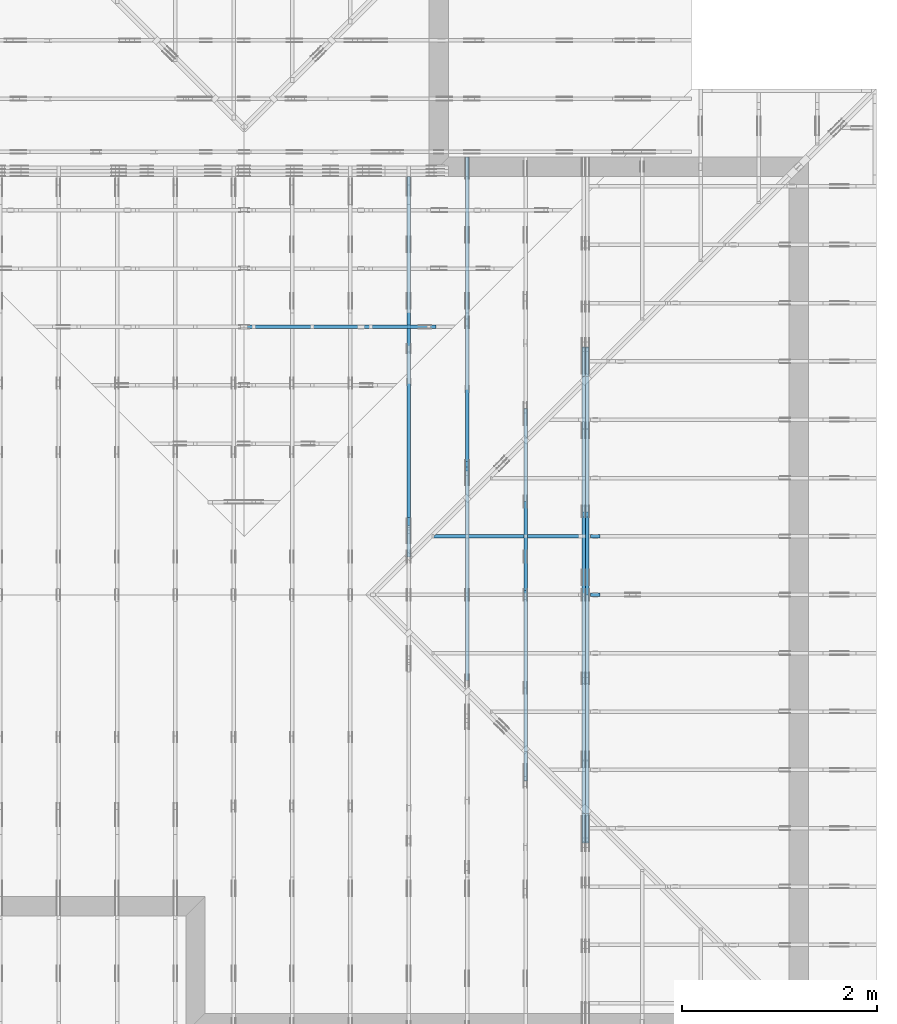
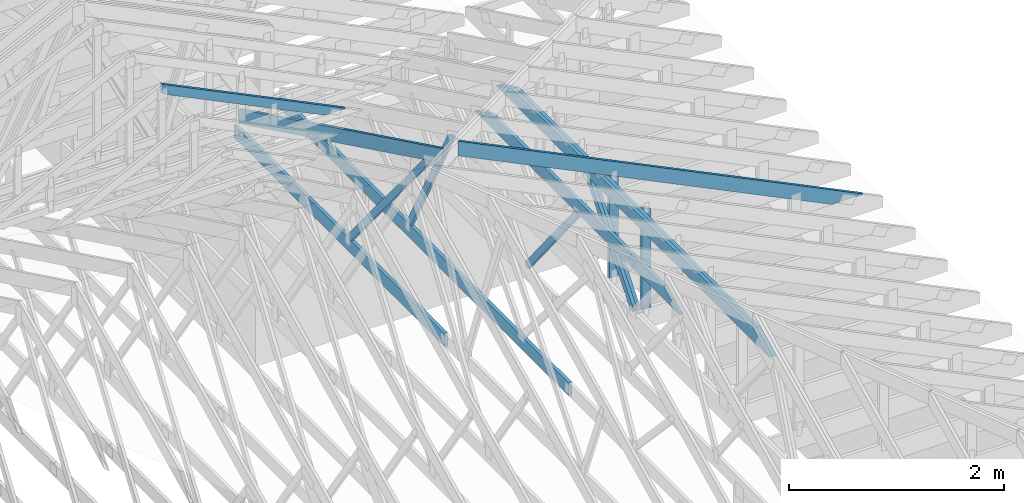
# One storey, part 33 of 159: 15 members, 7 elements without a shape of their own.
"""IFC2X3 building model written with IfcOpenShell, lengths in millimetres."""

from ifc_helpers import new_model, si_unit, frame, origin, origin_with_axes, origin_2d, place, context, project, spatial, faceted_brep, element, aggregate, save


model = new_model("IFC2X3")

# Units and contexts
model_context = context("Model", 3, precision=1e-05, world=origin())
plan_context = context("Plan", 2, precision=1e-05, world=origin_2d())
ifc_project = project(units=[si_unit("LENGTHUNIT", "METRE", prefix="MILLI"), si_unit("AREAUNIT", "SQUARE_METRE"), si_unit("VOLUMEUNIT", "CUBIC_METRE"), si_unit("SOLIDANGLEUNIT", "STERADIAN"), si_unit("PLANEANGLEUNIT", "RADIAN"), si_unit("MASSUNIT", "GRAM"), si_unit("TIMEUNIT", "SECOND"), si_unit("THERMODYNAMICTEMPERATUREUNIT", "DEGREE_CELSIUS"), si_unit("LUMINOUSINTENSITYUNIT", "LUMEN")], contexts=[model_context, plan_context])

# Site, building, storey
site_placement = place(None, origin_with_axes())
site = spatial("IfcSite", under=ifc_project, at=site_placement, CompositionType="ELEMENT")
building_placement = place(site_placement, origin_with_axes())
building = spatial("IfcBuilding", under=site, at=building_placement, Name="Plan 1", CompositionType="ELEMENT")
storey_placement = place(building_placement, origin_with_axes())
storey = spatial("IfcBuildingStorey", under=building, at=storey_placement, Name="Etasje 1", CompositionType="ELEMENT", Elevation=0.0)

# Assembly, members
assembly_1_placement = place(storey_placement, frame((16311.022261404749, -699.9989301294839, 1.1021457184401395e-15), z_axis=(1.0, -6.123031769111886e-17, 6.123031769111886e-17), x_axis=(6.123031769111886e-17, 1.0, 0.0)))
assembly_1 = element("IfcElementAssembly", 1, at=assembly_1_placement, inside=storey, Name="V8 (33)", AssemblyPlace="FACTORY", PredefinedType="TRUSS")
member_1_placement = place(assembly_1_placement, frame((5561.041284732537, 2315.452245697593, -36.00000332936904), z_axis=(0.0, 0.0, 1.0), x_axis=(0.8987940462991668, -0.4383711467890778, 0.0)))
member_1 = element("IfcMember", 2, at=member_1_placement, Name="V8-O18", context=model_context, shape_type="Brep", body=[
    faceted_brep([(112.23809390655876, 1.0096862743225188e-05, 36.00000636883472), (40.05366994714767, 148.00000490950697, 36.00000332936904), (-1.0658141036401503e-14, 148.00000458156322, 3.116920723300609e-06), (72.18442395941081, 9.768919051467151e-06, 6.15638617773584e-06), (4284.582819617043, 4.91022742784666e-06, 3.3293690364644135e-06), (4284.582819617043, 4.910227438044557e-06, 36.00000332936904), (112.23809305454324, 4.910228204466536e-06, 36.00000332936904), (72.18442407871316, 4.910228201626135e-06, 3.3293690364644135e-06), (7.641074262210168e-08, 148.0000049095188, 3.3293690364644135e-06), (40.05366905224082, 148.0000049095188, 36.00000332936904), (4212.398437576409, 148.00000490951854, 36.00000332936904), (4212.398437576409, 148.00000490951854, 3.3293690364644135e-06), (4212.3985236506915, 148.00000448254082, 1.9341692265584247e-06), (4212.398523650691, 148.00000448254082, 36.00000332936904), (4284.58294894472, -2.2737367544323206e-13, 36.00000302469259), (4284.58294894472, -2.2737367544323206e-13, -3.2311742677852644e-27), (4212.398396509646, 148.00000490829825, 36.00000332936904), (40.05366994714768, 148.00000490829825, 36.00000332936904), (112.23809530115113, 4.909506969852373e-06, 36.00000332936904), (4284.582966822146, 4.909506969852373e-06, 36.00000332936904), (8.594303608333576e-05, 148.00000490951788, 3.329369036464424e-06), (4212.398523443036, 148.00000490951788, 3.3293695523174132e-06), (4284.5829487970395, 4.908298251393717e-06, 3.329369561157164e-06), (72.18465625553517, 4.908298251393717e-06, 3.3293690453041925e-06)], [[[0, 1, 2, 3]], [[4, 5, 6, 7]], [[8, 9, 10, 11]], [[12, 13, 14, 15]], [[16, 17, 18, 19]], [[20, 21, 22, 23]]]),
])
member_2_placement = place(assembly_1_placement, frame((9501.9990234375, 371.000000000001, -36.0), z_axis=(0.0, 0.0, 1.0), x_axis=(-1.0, 1.2246063538223773e-16, 0.0)))
member_2 = element("IfcMember", 3, at=member_2_placement, Name="V8-U39", context=model_context, shape_type="Brep", body=[
    faceted_brep([(3910.81787109375, 148.00000000000148, 36.0), (0.0, 148.00000000000148, 36.0), (0.0, 1.0231815394945443e-12, 36.0), (3910.81787109375, 1.0231815394945443e-12, 36.0), (0.0, 148.00000000000148, 0.0), (3910.81787109375, 148.00000000000148, 4.789212413583509e-13), (3910.81787109375, 1.0231815394945443e-12, 4.789212413583509e-13), (0.0, 1.0231815394945443e-12, 0.0), (9.331764886155725e-05, 1.0231815394945443e-12, 0.0), (9.331764886376154e-05, 1.0231815394945443e-12, 36.0), (9.331764888188571e-05, 148.000000000001, 36.0), (9.331764887968142e-05, 148.000000000001, -1.1097486696621528e-30), (3910.817727755755, 3.047997282014717e-13, -1.8662984189942796e-29), (3910.817727755755, 3.07004019638352e-13, 36.0), (9.331764886155725e-05, 1.0253858382043776e-12, 36.0), (9.331764886155725e-05, 1.0231815467674973e-12, -4.453252306857598e-37), (3910.817727755755, 147.99999999999997, 0.0), (3910.817727755755, 147.99999999999997, 36.0), (3910.817727755755, 0.0, 36.0), (3910.817727755755, 0.0, 0.0), (9.331764886155725e-05, 148.000000000001, 0.0), (9.331764886155725e-05, 148.000000000001, 36.0), (3910.817727755755, 147.9999999999999, 36.0), (3910.817727755755, 147.9999999999999, -4.733165431326071e-30)], [[[0, 1, 2, 3]], [[4, 5, 6, 7]], [[8, 9, 10, 11]], [[12, 13, 14, 15]], [[16, 17, 18, 19]], [[20, 21, 22, 23]]]),
])
member_3_placement = place(assembly_1_placement, frame((5867.168446855473, 2143.081534588328, -36.00000000000001), z_axis=(0.0, 0.0, 1.0), x_axis=(0.635724001697691, -0.7719164421525652, 0.0)))
member_3 = element("IfcMember", 4, at=member_3_placement, Name="V8-D11", context=model_context, shape_type="Brep", body=[
    faceted_brep([(2355.811184781885, 73.00000224593168, 36.0), (110.0547770258413, 73.00000224593168, 36.0), (30.060308752150377, 36.500202761613764, 36.0), (0.0, 1.3182485417928547e-05, 36.0), (2295.690877689694, 1.3182485417928547e-05, 36.0), (110.0547770258413, 73.00000224593168, 1.3477377921435025e-14), (2355.811184781885, 73.00000224593168, 2.884941345289719e-13), (2295.690877689694, 1.3182485417928547e-05, 2.811317635230869e-13), (0.0, 1.3182485417928547e-05, 0.0), (30.060308752150377, 36.500202761613764, 3.681204509574577e-15), (30.060182805618297, 36.50014367218955, 3.2817687024750364e-31), (30.060182805618297, 36.50014367218955, 36.0), (110.05480683032465, 73.00014367069252, 36.0), (110.05480683032465, 73.00014367069252, 2.0469648002032677e-31), (3.0183125091018983e-05, 0.00014367069252315662, -1.3917853113735884e-32), (3.0183125092720517e-05, 0.00014367069252175529, 36.0), (30.060182805618304, 36.50014367218954, 36.0), (30.060182805618304, 36.50014367218954, -5.9819459304306e-31), (2295.690996011965, 0.00014367069210160344, -2.9867967065015177e-29), (2295.690996011965, 0.00014367069210380773, 36.0), (3.0183125090843532e-05, 0.0001436706925255054, 36.0), (3.0183125090843532e-05, 0.0001436706925233011, 0.0), (2355.8113012544836, 73.00014367069207, -3.4820787502978807e-29), (2355.8113012544836, 73.00014367069207, 36.0), (2295.6909960119647, 0.0001436706918411801, 36.0), (2295.6909960119647, 0.0001436706918411801, -3.4237955980755655e-29), (110.05480683032465, 73.00014367069251, -7.888609052210118e-31), (110.05480683032465, 73.00014367069251, 36.0), (2355.811301254484, 73.00014367069137, 36.0), (2355.811301254484, 73.00014367069137, -1.4199496293978212e-29)], [[[0, 1, 2, 3, 4]], [[5, 6, 7, 8, 9]], [[10, 11, 12, 13]], [[14, 15, 16, 17]], [[18, 19, 20, 21]], [[22, 23, 24, 25]], [[26, 27, 28, 29]]]),
])
aggregate(assembly_1, [member_1, member_2, member_3])

assembly_2_placement = place(storey_placement, frame((18074.541652722903, -699.9989301294845, 4.408582873760558e-15), z_axis=(-1.0, 1.836909530733566e-16, 6.123031769111886e-17), x_axis=(-1.836909530733566e-16, -1.0, 0.0)))
assembly_2 = element("IfcElementAssembly", 5, at=assembly_2_placement, inside=storey, Name="V5 (30)", AssemblyPlace="FACTORY", PredefinedType="TRUSS")
member_4_placement = place(assembly_2_placement, frame((-7749.97314453125, 1247.8388671875, -36.0), z_axis=(0.0, 0.0, 1.0), x_axis=(1.0, 0.0, 0.0)))
member_4 = element("IfcMember", 6, at=member_4_placement, Name="V5-O4", context=model_context, shape_type="Brep", body=[
    faceted_brep([(4796.502197265625, 148.0, 36.0), (303.4453125, 148.0, 36.0), (0.0, 0.0, 36.0), (5099.947265625, 0.0, 36.0), (303.4453125, 148.0, 3.7160105772511684e-14), (4796.502197265625, 148.0, 5.873827066894478e-13), (5099.947265625, 0.0, 6.245427825643434e-13), (0.0, 0.0, 0.0), (0.00010000774636626037, 3.0575836722509256e-05, 3.333008545782448e-31), (0.00010000774636722667, 3.057583672052805e-05, 36.0), (303.44506856109365, 148.0000305758294, 36.0), (303.44506856109365, 148.0000305758294, -1.3107526806544825e-30), (5099.947258925371, 3.057584031046555e-05, 2.255179239006228e-28), (5099.947258925371, 3.057584031266984e-05, 36.0), (0.00010000774636864664, 3.0575836719820984e-05, 36.0), (0.00010000774636864664, 3.057583671761669e-05, 4.513898307157584e-36), (4796.502290371908, 148.00003057584422, 2.524354896707238e-29), (4796.502290371908, 148.00003057584422, 36.0), (5099.947258925372, 3.057584444832173e-05, 36.0), (5099.947258925372, 3.057584444832173e-05, 2.524354896707238e-29), (303.4450685610937, 148.00003057582944, 1.5777218104420236e-30), (303.4450685610937, 148.00003057582944, 36.0), (4796.502290371907, 148.00003057584414, 36.0), (4796.502290371907, 148.00003057584414, 9.466330862652142e-30)], [[[0, 1, 2, 3]], [[4, 5, 6, 7]], [[8, 9, 10, 11]], [[12, 13, 14, 15]], [[16, 17, 18, 19]], [[20, 21, 22, 23]]]),
])
member_5_placement = place(assembly_2_placement, frame((-7749.97314453125, 1247.8388671875, -72.0), z_axis=(0.0, 0.0, 1.0), x_axis=(1.0, 0.0, 0.0)))
member_5 = element("IfcMember", 7, at=member_5_placement, Name="V5-O4", context=model_context, shape_type="Brep", body=[
    faceted_brep([(4796.502197265625, 148.0, 36.0), (303.4453125, 148.0, 36.0), (0.0, 0.0, 36.0), (5099.947265625, 0.0, 36.0), (303.4453125, 148.0, 3.7160105772511684e-14), (4796.502197265625, 148.0, 5.873827066894478e-13), (5099.947265625, 0.0, 6.245427825643434e-13), (0.0, 0.0, 0.0), (0.00010000774636626037, 3.0575836722509256e-05, 3.333008545782448e-31), (0.00010000774636722667, 3.057583672052805e-05, 36.0), (303.44506856109365, 148.0000305758294, 36.0), (303.44506856109365, 148.0000305758294, -1.3107526806544825e-30), (5099.947258925371, 3.057584031046555e-05, 2.255179239006228e-28), (5099.947258925371, 3.057584031266984e-05, 36.0), (0.00010000774636864664, 3.0575836719820984e-05, 36.0), (0.00010000774636864664, 3.057583671761669e-05, 4.513898307157584e-36), (4796.502290371908, 148.00003057584422, 2.524354896707238e-29), (4796.502290371908, 148.00003057584422, 36.0), (5099.947258925372, 3.057584444832173e-05, 36.0), (5099.947258925372, 3.057584444832173e-05, 2.524354896707238e-29), (303.4450685610937, 148.00003057582944, 1.5777218104420236e-30), (303.4450685610937, 148.00003057582944, 36.0), (4796.502290371907, 148.00003057584414, 36.0), (4796.502290371907, 148.00003057584414, 9.466330862652142e-30)], [[[0, 1, 2, 3]], [[4, 5, 6, 7]], [[8, 9, 10, 11]], [[12, 13, 14, 15]], [[16, 17, 18, 19]], [[20, 21, 22, 23]]]),
])
member_6_placement = place(assembly_2_placement, frame((-6078.085223416164, 1224.5375675646328, -36.0), z_axis=(0.0, 0.0, 1.0), x_axis=(0.6383914022223909, -0.769711905565017, 0.0)))
member_6 = element("IfcMember", 8, at=member_6_placement, Name="V5-D37", context=model_context, shape_type="Brep", body=[
    faceted_brep([(1287.4495130720438, 73.00005541108385, 36.0), (30.272782133609326, 73.00005541108385, 36.0), (0.0, 36.50002105565727, 36.0), (56.72773236313333, 0.00015764237878101994, 36.0), (1301.184976253474, 0.00015764237878101994, 36.0), (1331.4577583870832, 36.50002105565727, 36.0), (30.272782133609326, 73.00005541108385, 3.7072241348698525e-15), (1287.4495130720438, 73.00005541108385, 1.5766188539335507e-13), (1331.4577583870832, 36.50002105565727, 1.6305116307669217e-13), (1301.184976253474, 0.00015764237878101994, 1.5934393894182231e-13), (56.72773236313333, 0.00015764237878101994, 6.946914148982837e-15), (0.0, 36.50002105565727, 0.0), (1.7602400468774704e-05, 36.50009017409412, 7.888609052210118e-31), (1.7602400468774704e-05, 36.50009017409412, 36.0), (30.27275472995279, 73.00009017409413, 36.0), (30.27275472995279, 73.00009017409413, 9.860761315262648e-31), (56.72760760629533, 9.017409453448977e-05, 2.46700441303521e-30), (56.72760760629533, 9.017409453804248e-05, 36.0), (1.7602400490090986e-05, 36.500090174094126, 36.0), (1.7602400490090986e-05, 36.500090174094126, -1.0615723560387236e-30), (1301.1850510429695, 9.01740921197258e-05, 1.0592944961022604e-29), (1301.1850510429695, 9.017409212193009e-05, 36.0), (56.72760760629535, 9.017409456112615e-05, 36.0), (56.72760760629535, 9.017409455892186e-05, 4.61819192754446e-31), (1331.4577881705236, 36.50009017409457, 1.262177448353619e-29), (1331.4577881705236, 36.50009017409457, 36.0), (1301.1850510429695, 9.017409229272744e-05, 36.0), (1301.1850510429695, 9.017409229272744e-05, 0.0), (1287.4495442384823, 73.00009017409172, -6.310887241768095e-30), (1287.4495442384823, 73.00009017409172, 36.0), (1331.4577881705236, 36.50009017409445, 36.0), (1331.4577881705236, 36.50009017409445, -6.310887241768095e-30), (30.272754729952794, 73.00009017409411, 7.888609052210118e-31), (30.272754729952794, 73.00009017409411, 36.0), (1287.4495442384823, 73.0000901740918, 36.0), (1287.4495442384823, 73.00009017409181, -2.3665827156630354e-30)], [[[0, 1, 2, 3, 4, 5]], [[6, 7, 8, 9, 10, 11]], [[12, 13, 14, 15]], [[16, 17, 18, 19]], [[20, 21, 22, 23]], [[24, 25, 26, 27]], [[28, 29, 30, 31]], [[32, 33, 34, 35]]]),
])
member_7_placement = place(assembly_2_placement, frame((-6078.085223416164, 1224.5375675646328, -72.0), z_axis=(0.0, 0.0, 1.0), x_axis=(0.6383914022223909, -0.769711905565017, 0.0)))
member_7 = element("IfcMember", 9, at=member_7_placement, Name="V5-D37", context=model_context, shape_type="Brep", body=[
    faceted_brep([(1287.4495130720438, 73.00005541108385, 36.0), (30.272782133609326, 73.00005541108385, 36.0), (0.0, 36.50002105565727, 36.0), (56.72773236313333, 0.00015764237878101994, 36.0), (1301.184976253474, 0.00015764237878101994, 36.0), (1331.4577583870832, 36.50002105565727, 36.0), (30.272782133609326, 73.00005541108385, 3.7072241348698525e-15), (1287.4495130720438, 73.00005541108385, 1.5766188539335507e-13), (1331.4577583870832, 36.50002105565727, 1.6305116307669217e-13), (1301.184976253474, 0.00015764237878101994, 1.5934393894182231e-13), (56.72773236313333, 0.00015764237878101994, 6.946914148982837e-15), (0.0, 36.50002105565727, 0.0), (1.7602400468774704e-05, 36.50009017409412, 7.888609052210118e-31), (1.7602400468774704e-05, 36.50009017409412, 36.0), (30.27275472995279, 73.00009017409413, 36.0), (30.27275472995279, 73.00009017409413, 9.860761315262648e-31), (56.72760760629533, 9.017409453448977e-05, 2.46700441303521e-30), (56.72760760629533, 9.017409453804248e-05, 36.0), (1.7602400490090986e-05, 36.500090174094126, 36.0), (1.7602400490090986e-05, 36.500090174094126, -1.0615723560387236e-30), (1301.1850510429695, 9.01740921197258e-05, 1.0592944961022604e-29), (1301.1850510429695, 9.017409212193009e-05, 36.0), (56.72760760629535, 9.017409456112615e-05, 36.0), (56.72760760629535, 9.017409455892186e-05, 4.61819192754446e-31), (1331.4577881705236, 36.50009017409457, 1.262177448353619e-29), (1331.4577881705236, 36.50009017409457, 36.0), (1301.1850510429695, 9.017409229272744e-05, 36.0), (1301.1850510429695, 9.017409229272744e-05, 0.0), (1287.4495442384823, 73.00009017409172, -6.310887241768095e-30), (1287.4495442384823, 73.00009017409172, 36.0), (1331.4577881705236, 36.50009017409445, 36.0), (1331.4577881705236, 36.50009017409445, -6.310887241768095e-30), (30.272754729952794, 73.00009017409411, 7.888609052210118e-31), (30.272754729952794, 73.00009017409411, 36.0), (1287.4495442384823, 73.0000901740918, 36.0), (1287.4495442384823, 73.00009017409181, -2.3665827156630354e-30)], [[[0, 1, 2, 3, 4, 5]], [[6, 7, 8, 9, 10, 11]], [[12, 13, 14, 15]], [[16, 17, 18, 19]], [[20, 21, 22, 23]], [[24, 25, 26, 27]], [[28, 29, 30, 31]], [[32, 33, 34, 35]]]),
])
aggregate(assembly_2, [member_4, member_5, member_6, member_7])

assembly_3_placement = place(storey_placement, frame((17475.02226140475, -699.9989301294827, 1.1021457184401395e-15), z_axis=(-1.0, 1.836909530733566e-16, 6.123031769111886e-17), x_axis=(-1.836909530733566e-16, -1.0, 0.0)))
assembly_3 = element("IfcElementAssembly", 10, at=assembly_3_placement, inside=storey, Name="V6 (31)", AssemblyPlace="FACTORY", PredefinedType="TRUSS")
member_8_placement = place(assembly_3_placement, frame((-7114.45361328125, 1557.802490234375, -36.0), z_axis=(0.0, 0.0, 1.0), x_axis=(1.0, 0.0, 0.0)))
member_8 = element("IfcMember", 11, at=member_8_placement, Name="V6-O25", context=model_context, shape_type="Brep", body=[
    faceted_brep([(3525.463134765625, 148.0, 36.0), (303.4453125, 148.0, 36.0), (0.0, 0.0, 36.0), (3828.908203125, 0.0, 36.0), (303.4453125, 148.0, 3.7160105772511684e-14), (3525.463134765625, 148.0, 4.31730455500054e-13), (3828.908203125, 0.0, 4.688905313749496e-13), (0.0, 0.0, 0.0), (0.0001162944099572433, 1.5328769347060762e-06, 8.463003131754488e-31), (0.0001162944099582096, 1.532876932724873e-06, 36.0), (303.4450848480046, 148.00000153287684, 36.0), (303.4450848480046, 148.00000153287684, -3.648061267039187e-30), (3828.9081801386055, 1.5328762189475288e-06, 4.306547404322253e-29), (3828.9081801386055, 1.5328762211518203e-06, 36.0), (0.00011629440996330231, 1.5328769244875917e-06, 36.0), (0.00011629440996330231, 1.5328769222833002e-06, 1.3047987294127391e-36), (3525.463211585012, 148.0000015328692, -1.262177448353619e-29), (3525.463211585012, 148.0000015328692, 36.0), (3828.9081801386064, 1.5328762401622953e-06, 36.0), (3828.9081801386064, 1.5328762401622953e-06, -1.262177448353619e-29), (303.4450848480046, 148.00000153287692, -1.5777218104420236e-30), (303.4450848480046, 148.00000153287692, 36.0), (3525.463211585011, 148.00000153286956, 36.0), (3525.463211585011, 148.00000153286956, -6.310887241768095e-30)], [[[0, 1, 2, 3]], [[4, 5, 6, 7]], [[8, 9, 10, 11]], [[12, 13, 14, 15]], [[16, 17, 18, 19]], [[20, 21, 22, 23]]]),
])
member_9_placement = place(assembly_3_placement, frame((-5228.410091288182, 1580.7173568355051, -36.0), z_axis=(0.0, 0.0, 1.0), x_axis=(-0.6278034094766977, -0.7783719413297436, 0.0)))
member_9 = element("IfcMember", 12, at=member_9_placement, Name="V6-D28", context=model_context, shape_type="Brep", body=[
    faceted_brep([(1495.2845679345714, 73.0002484218221, 36.0), (45.253921440836166, 73.0002484218221, 36.0), (3.048273538297508e-05, 36.50002935365501, 36.0), (29.439350908762208, 0.00016228454296651762, 36.0), (1479.4702564390782, 0.00016228454296651762, 36.0), (1524.7241949052323, 36.50002935365501, 36.0), (45.253921440836166, 73.0002484218221, 5.541823973182668e-15), (1495.2845679345714, 73.0002484218221, 1.8311349826652243e-13), (1524.7241949052323, 36.50002935365501, 1.8671869369076562e-13), (1479.4702564390782, 0.00016228454296651762, 1.811768676326517e-13), (29.439350908762208, 0.00016228454296651762, 3.605161617527678e-15), (3.048273538297508e-05, 36.50002935365501, 3.732935143187748e-21), (3.552713678800501e-15, 36.50006470553216, -3.3843898568623427e-31), (3.552713678800501e-15, 36.50006470553216, 36.0), (45.25393686886902, 73.00006470553124, 36.0), (45.25393686886902, 73.00006470553124, -1.0911800401646925e-30), (29.439427642719238, 6.47055312530398e-05, 5.0833532784069106e-31), (29.439427642719238, 6.470553125481615e-05, 36.0), (1.0658141036401503e-14, 36.50006470553218, 36.0), (1.0658141036401503e-14, 36.50006470553218, -9.639549077254733e-31), (1479.4702068865313, 6.470552711836355e-05, 3.073924272552827e-29), (1479.4702068865313, 6.470552712056784e-05, 36.0), (29.439427642719238, 6.470553125058352e-05, 36.0), (29.439427642719238, 6.470553124837923e-05, 6.116685794899254e-31), (1524.7241437554399, 36.50006470553069, 3.7865323450608567e-29), (1524.7241437554399, 36.50006470553069, 36.0), (1479.4702068865317, 6.470552693826903e-05, 36.0), (1479.4702068865317, 6.470552693826903e-05, 3.7865323450608567e-29), (1495.2847161127233, 73.00006470552773, 1.262177448353619e-29), (1495.2847161127233, 73.00006470552773, 36.0), (1524.7241437554394, 36.50006470553137, 36.0), (1524.7241437554394, 36.50006470553137, 1.262177448353619e-29), (45.253936868869005, 73.00006470553126, 0.0), (45.253936868869005, 73.00006470553126, 36.0), (1495.2847161127233, 73.00006470552762, 36.0), (1495.2847161127233, 73.00006470552763, 0.0)], [[[0, 1, 2, 3, 4, 5]], [[6, 7, 8, 9, 10, 11]], [[12, 13, 14, 15]], [[16, 17, 18, 19]], [[20, 21, 22, 23]], [[24, 25, 26, 27]], [[28, 29, 30, 31]], [[32, 33, 34, 35]]]),
])
aggregate(assembly_3, [member_8, member_9])

assembly_4_placement = place(storey_placement, frame((16875.02226140475, -699.9989301294827, 1.1021457184401395e-15), z_axis=(-1.0, 1.836909530733566e-16, 6.123031769111886e-17), x_axis=(-1.836909530733566e-16, -1.0, 0.0)))
assembly_4 = element("IfcElementAssembly", 13, at=assembly_4_placement, inside=storey, Name="V7 (32)", AssemblyPlace="FACTORY", PredefinedType="TRUSS")
member_10_placement = place(assembly_4_placement, frame((-4319.998923973908, 371.0, -36.0), z_axis=(0.0, 0.0, 1.0), x_axis=(-1.0, 1.2246063538223773e-16, 0.0)))
member_10 = element("IfcMember", 14, at=member_10_placement, Name="V7-U33", context=model_context, shape_type="Brep", body=[
    faceted_brep([(5380.000099463592, 148.00000000000068, 36.0), (9.946359205059707e-05, 148.00000000000068, 36.0), (9.946359205059707e-05, 0.0, 36.0), (5380.000099463592, 0.0, 36.0), (9.946359205059707e-05, 148.00000000000068, 1.2180374679915807e-20), (5380.000099463592, 148.00000000000068, 6.588382305368136e-13), (5380.000099463592, 0.0, 6.588382305368136e-13), (9.946359205059707e-05, 0.0, 1.2180374679915807e-20), (5.56886495279458e-29, 4.547473508864641e-13, -3.409833702385498e-45), (2.2042914368803347e-15, 4.547473508864641e-13, 36.0), (2.0328465473451522e-14, 148.00000000000048, 36.0), (1.8124174036571243e-14, 148.00000000000048, -1.1097489341483854e-30), (5380.0, -5.335099766481943e-13, 7.44334725075097e-29), (5380.0, -5.31305685211314e-13, 36.0), (4.049083948919771e-31, 4.569516423233444e-13, 36.0), (0.0, 4.547473508864641e-13, 0.0), (5380.0, 148.00000000000068, 0.0), (5380.0, 148.00000000000068, 36.0), (5380.0, 6.821210263296962e-13, 36.0), (5380.0, 6.821210263296962e-13, 0.0), (0.0, 148.00000000000048, 0.0), (0.0, 148.00000000000048, 36.0), (5380.0, 148.00000000000014, 36.0), (5380.0, 148.00000000000014, -3.155443620884047e-29)], [[[0, 1, 2, 3]], [[4, 5, 6, 7]], [[8, 9, 10, 11]], [[12, 13, 14, 15]], [[16, 17, 18, 19]], [[20, 21, 22, 23]]]),
])
member_11_placement = place(assembly_4_placement, frame((-6537.609034611222, 1884.6686161511989, -36.0), z_axis=(0.0, 0.0, 1.0), x_axis=(-0.46885659839708677, -0.88327430062213, 0.0)))
member_11 = element("IfcMember", 15, at=member_11_placement, Name="V7-D20", context=model_context, shape_type="Brep", body=[
    faceted_brep([(1674.9520599534505, 72.99994697148577, 36.0), (0.0, 72.99994697148577, 36.0), (19.374903700655977, 36.49995562038475, 36.0), (69.53925289847393, 9.233289893018082e-05, 36.0), (1713.701638420877, 9.233289893018082e-05, 36.0), (0.0, 72.99994697148577, 0.0), (1674.9520599534505, 72.99994697148577, 2.051156934966875e-13), (1713.701638420877, 9.233289893018082e-05, 2.098609914966024e-13), (69.53925289847393, 9.233289893018082e-05, 8.515821093953234e-15), (19.374903700655977, 36.49995562038475, 2.372663017652e-15), (19.374824175186404, 36.500045066932216, -7.135350925489249e-32), (19.374824175186404, 36.500045066932216, 36.0), (2.0865909636569313e-05, 73.0000450694888, 36.0), (2.08659096330166e-05, 73.0000450694888, -9.875523305466793e-31), (69.53926649391771, 4.5069487882187786e-05, 7.888609052210117e-31), (69.53926649391771, 4.5069487882187786e-05, 36.0), (19.374824175186408, 36.500045066932216, 36.0), (19.374824175186408, 36.500045066932216, -8.758115402030107e-47), (1713.7016144969778, 4.5069486098001124e-05, 5.442780225019166e-29), (1713.7016144969778, 4.5069486100205415e-05, 36.0), (69.5392664939177, 4.506948786253268e-05, 36.0), (69.5392664939177, 4.506948786032839e-05, 2.208593265646982e-30), (1674.9520078811297, 73.0000450694879, -1.262177448353619e-29), (1674.9520078811297, 73.0000450694879, 36.0), (1713.7016144969775, 4.506948698690394e-05, 36.0), (1713.7016144969775, 4.506948698690394e-05, -1.262177448353619e-29), (2.0865909618805745e-05, 73.0000450694888, 0.0), (2.0865909618805745e-05, 73.0000450694888, 36.0), (1674.95200788113, 73.00004506948795, 36.0), (1674.95200788113, 73.00004506948795, 3.944304526105059e-30)], [[[0, 1, 2, 3, 4]], [[5, 6, 7, 8, 9]], [[10, 11, 12, 13]], [[14, 15, 16, 17]], [[18, 19, 20, 21]], [[22, 23, 24, 25]], [[26, 27, 28, 29]]]),
])
aggregate(assembly_4, [member_10, member_11])

# Assembly, member
assembly_5_placement = place(storey_placement, frame((21100.012663101486, 4518.000534935253, 1.1021457184401395e-15), z_axis=(1.2246063538223773e-16, 1.0, 6.123031769111886e-17), x_axis=(-1.0, 1.2246063538223773e-16, 0.0)))
assembly_5 = element("IfcElementAssembly", 16, at=assembly_5_placement, inside=storey, Name="S13 (51)", AssemblyPlace="FACTORY", PredefinedType="TRUSS")
member_12_placement = place(assembly_5_placement, frame((2840.990401698568, 1388.7763671875, -36.0), z_axis=(0.0, 0.0, 1.0), x_axis=(-1.836909530733566e-16, -1.0, 0.0)))
member_12 = element("IfcMember", 17, at=member_12_placement, Name="S13-S8", context=model_context, shape_type="Brep", body=[
    faceted_brep([(1165.7763671875, 98.00007681705756, 36.0), (0.0, 98.00007681705756, 36.0), (47.7978515625, 7.681705710638198e-05, 36.0), (1165.7763671875, 7.681705710638198e-05, 36.0), (0.0, 98.00007681705756, 0.0), (1165.7763671875, 98.00007681705756, 1.4276171463937812e-13), (1165.7763671875, 7.681705710638198e-05, 1.4276171463937812e-13), (47.7978515625, 7.681705710638198e-05, 5.853355272249634e-15), (47.79785166565126, 1.4097167877480388e-11, -8.534279347868018e-31), (47.79785166565126, 1.4097167877480388e-11, 36.0), (5.7986202598669934e-05, 98.00000000001408, 36.0), (5.7986202598669934e-05, 98.00000000001408, -5.174379307103902e-31), (1165.776367187592, -1.0110684934954762e-14, 6.190804506420558e-31), (1165.776367187592, -7.906393498074482e-15, 36.0), (47.79785166565125, 1.409895762198326e-11, 36.0), (47.79785166565125, 1.409675333054638e-11, 2.5382840467290616e-32), (1165.776367187592, 97.99999999998545, 3.736045247126712e-27), (1165.776367187592, 97.99999999998545, 36.0), (1165.776367187592, 0.0, 36.0), (1165.776367187592, 0.0, 0.0), (5.7986202591564506e-05, 98.0000000000141, 0.0), (5.7986202591564506e-05, 98.0000000000141, 36.0), (1165.7763671875312, 97.99999999998555, 36.0), (1165.7763671875312, 97.99999999998555, 6.310887241768095e-30)], [[[0, 1, 2, 3]], [[4, 5, 6, 7]], [[8, 9, 10, 11]], [[12, 13, 14, 15]], [[16, 17, 18, 19]], [[20, 21, 22, 23]]]),
])
aggregate(assembly_5, [member_12])

# Assembly, members
assembly_6_placement = place(storey_placement, frame((21100.012663101486, 5117.993668449257, 1.1021457184401395e-15), z_axis=(1.2246063538223773e-16, 1.0, 6.123031769111886e-17), x_axis=(-1.0, 1.2246063538223773e-16, 0.0)))
assembly_6 = element("IfcElementAssembly", 18, at=assembly_6_placement, inside=storey, Name="S14 (49)", AssemblyPlace="FACTORY", PredefinedType="TRUSS")
member_13_placement = place(assembly_6_placement, frame((276.06011964609297, 89.97842920658336, -36.00000021753762), z_axis=(0.0, 0.0, 1.0), x_axis=(0.8987940462991673, 0.43837114678907685, 0.0)))
member_13 = element("IfcMember", 19, at=member_13_placement, Name="S14-O8", context=model_context, shape_type="Brep", body=[
    faceted_brep([(4846.397758917314, 148.00000083077396, 2.2532581169798505e-06), (4806.344091919934, 147.9999951379083, 35.99999718725712), (4734.159667968752, 3.2125149118655827e-07, 36.0000002175384), (4774.213337911325, -6.821210263296962e-13, 9.094947017729282e-13), (0.00034107614607137293, 148.00000032053072, 2.1753761814125028e-07), (0.00034107614607137293, 148.00000032053094, 36.00000021753762), (4806.344091076146, 148.00000032053066, 36.00000021753762), (4846.397760051976, 148.00000032053043, 2.1753761814125028e-07), (303.4450863820609, 3.210998755776018e-07, 2.1753761814125028e-07), (303.4450863820609, 3.210998755776018e-07, 36.00000021753762), (0.00011466892937050943, 148.0000018620399, 36.00000021753762), (0.00011466892937050943, 148.0000018620399, 2.1753761814125028e-07), (4774.213337825962, 3.2125240284538226e-07, 2.1753761814125028e-07), (4734.159668850132, 3.212524124071703e-07, 36.00000021753762), (303.4452714197128, 3.212532262893208e-07, 36.00000021753762), (303.4452714197128, 3.2125322408502934e-07, 2.1753761814125028e-07), (4806.344093322753, 148.00000032125195, 36.00000021753762), (0.0, 148.00000032125195, 36.00000021753762), (303.4453125000003, 3.210998045233282e-07, 36.00000021753762), (4734.15966796875, 3.210998045233282e-07, 36.00000021753762), (0.00029999585808582196, 148.00000032043124, 2.1753761814128702e-07), (4846.397760933358, 148.00000032043124, 2.175382116341994e-07), (4774.213335579354, 3.2053185350378044e-07, 2.1753820279444881e-07), (303.4451242146087, 3.2053185350378044e-07, 2.17537655301333e-07)], [[[0, 1, 2, 3]], [[4, 5, 6, 7]], [[8, 9, 10, 11]], [[12, 13, 14, 15]], [[16, 17, 18, 19]], [[20, 21, 22, 23]]]),
])
member_14_placement = place(assembly_6_placement, frame((2840.9904016985674, 1388.7763671875, -36.0), z_axis=(0.0, 0.0, 1.0), x_axis=(-1.836909530733566e-16, -1.0, 0.0)))
member_14 = element("IfcMember", 20, at=member_14_placement, Name="S14-S8", context=model_context, shape_type="Brep", body=[
    faceted_brep([(1165.7763671875, 98.00007681705802, 36.0), (0.0, 98.00007681705802, 36.0), (47.7978515625, 7.681705756112933e-05, 36.0), (1165.7763671875, 7.681705756112933e-05, 36.0), (0.0, 98.00007681705802, 0.0), (1165.7763671875, 98.00007681705802, 1.4276171463937812e-13), (1165.7763671875, 7.681705756112933e-05, 1.4276171463937812e-13), (47.7978515625, 7.681705756112933e-05, 5.853355272249634e-15), (47.79785166725196, -7.105427357601002e-15, 3.944304526105059e-31), (47.79785166725196, -7.105427357601002e-15, 36.0), (5.798778148147221e-05, 98.00000000001457, 36.0), (5.798778148147221e-05, 98.00000000001457, -3.944304526105059e-31), (1165.776367187592, -2.335847581209805e-13, 4.214679371152369e-29), (1165.776367187592, -2.313804666841002e-13, 36.0), (47.79785166725196, -2.6017927652632522e-14, 36.0), (47.79785166725196, -2.82222190895128e-14, 1.728055440799228e-30), (1165.776367187592, 97.9999999999859, 3.736045247126712e-27), (1165.776367187592, 97.9999999999859, 36.0), (1165.776367187592, 4.547473508864641e-13, 36.0), (1165.776367187592, 4.547473508864641e-13, 0.0), (5.7987781474366784e-05, 98.00000000001455, 0.0), (5.7987781474366784e-05, 98.00000000001455, 36.0), (1165.7763671875312, 97.999999999986, 36.0), (1165.7763671875312, 97.999999999986, 6.310887241768095e-30)], [[[0, 1, 2, 3]], [[4, 5, 6, 7]], [[8, 9, 10, 11]], [[12, 13, 14, 15]], [[16, 17, 18, 19]], [[20, 21, 22, 23]]]),
])
aggregate(assembly_6, [member_13, member_14])

# Assembly, member
assembly_7_placement = place(storey_placement, frame((12446.012607049342, 7236.0000560521385, 1312.9938842936408), z_axis=(0.0, -1.0, 6.123031769111886e-17), x_axis=(1.0, 0.0, 0.0)))
assembly_7 = element("IfcElementAssembly", 21, at=assembly_7_placement, inside=storey, Name="Tr3 (84)", AssemblyPlace="FACTORY", PredefinedType="TRUSS")
member_15_placement = place(assembly_7_placement, frame((2111.0396102732648, 962.4941977122187, -36.0), z_axis=(0.0, 0.0, 1.0), x_axis=(0.8987940462991671, -0.438371146789077, 0.0)))
member_15 = element("IfcMember", 22, at=member_15_placement, Name="Tr3-O83", context=model_context, shape_type="Brep", body=[
    faceted_brep([(2193.0166506512146, 98.00004745100819, 36.0), (0.0, 98.00004745100819, 36.0), (47.79781297353588, 0.0, 36.0), (1992.0868090718036, 0.0, 36.0), (0.0, 98.00004745100819, 0.0), (2193.0166506512146, 98.00004745100819, 2.685582124425746e-13), (1992.0868090718036, 0.0, 2.439522163755076e-13), (47.79781297353588, 0.0, 5.85335054662057e-15), (47.79785576077121, 4.013774241684587e-05, -1.1187244339002637e-30), (47.79785576077121, 4.013774241684587e-05, 36.0), (6.208183688016788e-05, 98.0000401366765, 36.0), (6.208183688016788e-05, 98.0000401366765, -1.8491448905835343e-30), (1992.0868678366514, 4.01369321742466e-05, -4.8941456775129893e-29), (1992.0868678366514, 4.0136932176450894e-05, 36.0), (47.7978557607712, 4.013774243822848e-05, 36.0), (47.7978557607712, 4.013774243602419e-05, -1.1742947823471604e-30), (2193.0166443123253, 98.00004013737077, 5.059177394201476e-29), (2193.0166443123253, 98.00004013737077, 36.0), (1992.0868678366517, 4.01369305791377e-05, 36.0), (1992.0868678366517, 4.01369305791377e-05, 5.128065553810798e-29), (6.20818368588516e-05, 98.00004013667649, 0.0), (6.20818368588516e-05, 98.00004013667649, 36.0), (2193.016644312325, 98.00004013737171, 36.0), (2193.016644312325, 98.00004013737171, 8.67746995743113e-30)], [[[0, 1, 2, 3]], [[4, 5, 6, 7]], [[8, 9, 10, 11]], [[12, 13, 14, 15]], [[16, 17, 18, 19]], [[20, 21, 22, 23]]]),
])
aggregate(assembly_7, [member_15])

save(model, "model.ifc")
